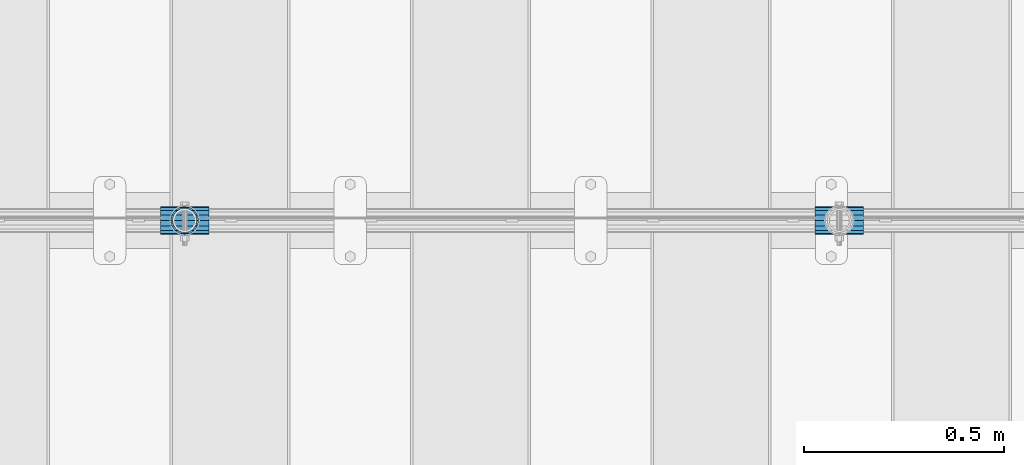
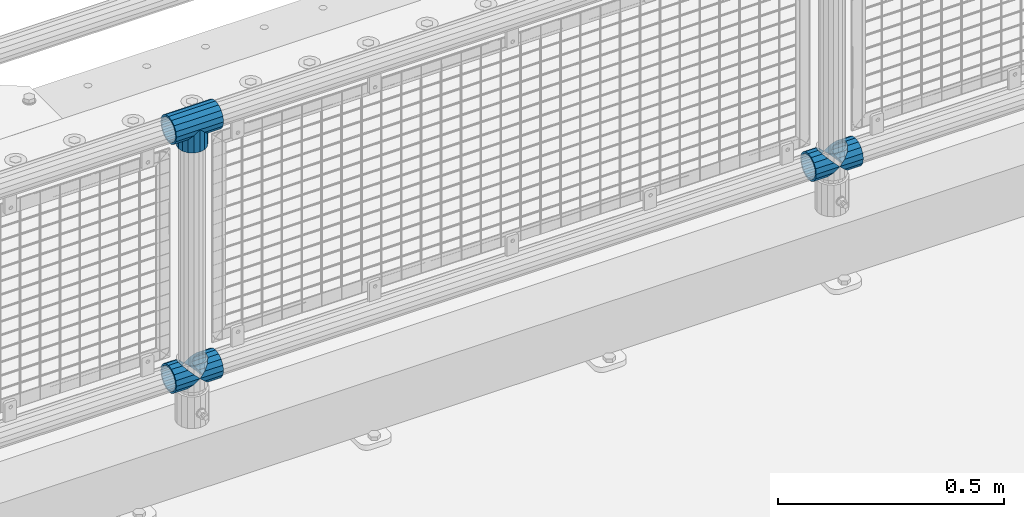
# One storey, part 147 of 242: 6 beams.
"""IFC2X3 building model written with IfcOpenShell, lengths in millimetres."""

from ifc_helpers import new_model, si_unit, frame, origin_with_axes, place, context, subcontext, project, spatial, faceted_brep, material, type_object, element, save


model = new_model("IFC2X3")

# Units and contexts
model_context = context("Model", 3, precision=1e-05, world=origin_with_axes())
body_context = subcontext(model_context, "Body", "Model", "MODEL_VIEW")
ifc_project = project(units=[si_unit("LENGTHUNIT", "METRE", prefix="MILLI"), si_unit("AREAUNIT", "SQUARE_METRE"), si_unit("VOLUMEUNIT", "CUBIC_METRE"), si_unit("MASSUNIT", "GRAM", prefix="KILO"), si_unit("TIMEUNIT", "SECOND"), si_unit("PLANEANGLEUNIT", "RADIAN"), si_unit("SOLIDANGLEUNIT", "STERADIAN"), si_unit("THERMODYNAMICTEMPERATUREUNIT", "DEGREE_CELSIUS"), si_unit("LUMINOUSINTENSITYUNIT", "LUMEN")], contexts=[model_context])

# Site, building, storey
site_placement = place(None, origin_with_axes())
site = spatial("IfcSite", under=ifc_project, at=site_placement, CompositionType="ELEMENT")
building_placement = place(site_placement, origin_with_axes())
building = spatial("IfcBuilding", under=site, at=building_placement, Name="Standard", CompositionType="ELEMENT")
storey_placement = place(building_placement, origin_with_axes())
storey = spatial("IfcBuildingStorey", under=building, at=storey_placement, Name="Undefined", CompositionType="ELEMENT", Elevation=0.0)

# Beams
ifc_material = material(Name="Misc_Undefined")
beam_type = type_object("IfcBeamType", PredefinedType="NOTDEFINED")
beam_1_placement = place(storey_placement, frame((-36990.15, -19335.5, 298.17), z_axis=(0.0, 1.0, 0.0), x_axis=(1.0, 0.0, 0.0)))
element("IfcBeam", 1, at=beam_1_placement, inside=storey, type_object=beam_type, material=ifc_material, context=body_context, shape_type="Brep", body=[
    faceted_brep([(60.1500000000015, 0.0, -35.1500000000015), (46.698677352364, 13.4513226476329, -32.4743655677703), (46.698677352364, -13.4513226476329, -32.4743655677703), (33.0273231408901, 21.4606908090117, 21.46069080901), (27.6756344322275, 26.8123795176754, 13.4513226476338), (27.6756344322275, 32.4743655677717, 13.4513226476338), (35.2951966412911, 24.8548033587072, 24.8548033587067), (35.2951966412911, 16.3810424080013, 24.8548033587067), (27.3102561882806, 28.0397438117175, 11.614442172282), (24.9999999999964, 30.35, 0.0), (24.9999999999964, 35.15, 0.0), (27.6756344322275, 26.8123795176754, -13.4513226476338), (27.6756344322275, 32.4743655677717, -13.4513226476338), (27.310256188277, 28.0397438117175, -11.614442172282), (35.2951966412911, 16.3810424080013, -24.8548033587067), (35.2951966412911, 24.8548033587072, -24.8548033587067), (33.0273231408937, 21.4606908090117, -21.46069080901), (40.061796877013, 11.6144421722805, -28.0397438117179), (43.5193396016293, 0.0, -30.3499999999985), (40.061796877013, -11.6144421722805, -28.0397438117179), (35.2951966412911, -16.3810424080078, -24.8548033587067), (35.2951966412911, -24.8548033587072, -24.8548033587067), (33.0273231408937, -21.4606908090117, -21.46069080901), (27.6756344322275, -26.8123795176754, -13.4513226476338), (27.6756344322275, -32.4743655677717, -13.4513226476338), (27.310256188277, -28.0397438117175, -11.614442172282), (24.9999999999964, -30.35, 0.0), (24.9999999999964, -35.15, 0.0), (27.3102561882806, -28.0397438117175, 11.614442172282), (27.6756344322275, -26.8123795176775, 13.4513226476338), (27.6756344322275, -32.4743655677717, 13.4513226476338), (33.0273231408901, -21.4606908090117, 21.46069080901), (35.2951966412911, -16.3810424080045, 24.8548033587067), (35.2951966412911, -24.8548033587072, 24.8548033587067), (60.1500000000015, 0.0, 35.1500000000015), (46.698677352364, -13.4513226476329, 32.4743655677703), (46.698677352364, 13.4513226476329, 32.4743655677703), (40.0617968770166, -11.6144421722805, 28.0397438117179), (43.5193396016257, 0.0, 30.3499999999985), (40.0617968770166, 11.6144421722805, 28.0397438117179), (0.0, -32.4743655677703, -13.4513226476338), (0.0, -24.8548033587067, -24.8548033587067), (0.0, -13.4513226476338, -32.4743655677739), (0.0, 0.0, -35.1500000000015), (0.0, 13.4513226476338, -32.4743655677739), (0.0, 24.8548033587067, -24.8548033587067), (0.0, 32.4743655677703, -13.4513226476338), (0.0, 35.1500000000015, 0.0), (0.0, 32.4743655677703, 13.4513226476338), (0.0, 24.8548033587067, 24.8548033587067), (0.0, 13.4513226476338, 32.4743655677739), (0.0, 0.0, 35.1500000000015), (0.0, -32.4743655677703, 13.4513226476338), (0.0, -35.1500000000015, 0.0), (0.0, -24.8548033587067, 24.8548033587067), (0.0, -13.4513226476338, 32.4743655677739), (0.0, -28.0397438117179, -11.6144421722784), (0.0, -21.46069080901, -21.4606908090136), (0.0, -11.614442172282, -28.0397438117143), (0.0, 0.0, -30.3499999999985), (0.0, 11.614442172282, -28.0397438117143), (0.0, 21.46069080901, -21.4606908090136), (0.0, 28.0397438117179, -11.6144421722784), (0.0, 30.3499999999985, 0.0), (0.0, 28.0397438117179, 11.6144421722784), (0.0, 21.46069080901, 21.4606908090136), (0.0, 11.614442172282, 28.0397438117143), (0.0, 0.0, 30.3499999999985), (0.0, -11.614442172282, 28.0397438117143), (0.0, -21.46069080901, 21.4606908090136), (0.0, -28.0397438117179, 11.6144421722784), (0.0, -30.3499999999985, 0.0)], [[[0, 1, 2]], [[3, 4, 5, 6, 7]], [[8, 9, 10, 5, 4]], [[11, 12, 10, 9, 13]], [[14, 15, 12, 11, 16]], [[2, 1, 15, 14, 17, 18, 19, 20, 21]], [[21, 20, 22, 23, 24]], [[24, 23, 25, 26, 27]], [[27, 26, 28, 29, 30]], [[30, 29, 31, 32, 33]], [[34, 35, 36]], [[33, 32, 37, 38, 39, 7, 6, 36, 35]], [[40, 41, 21, 24]], [[41, 42, 2, 21]], [[42, 43, 0, 2]], [[43, 44, 1, 0]], [[44, 45, 15, 1]], [[45, 46, 12, 15]], [[46, 47, 10, 12]], [[47, 48, 5, 10]], [[48, 49, 6, 5]], [[49, 50, 36, 6]], [[50, 51, 34, 36]], [[52, 53, 27, 30]], [[54, 52, 30, 33]], [[55, 54, 33, 35]], [[51, 55, 35, 34]], [[53, 40, 24, 27]], [[52, 54, 55, 51, 50, 49, 48, 47, 46, 45, 44, 43, 42, 41, 40, 53], [56, 57, 58, 59, 60, 61, 62, 63, 64, 65, 66, 67, 68, 69, 70, 71]], [[68, 67, 38, 37]], [[31, 69, 68, 37, 32]], [[28, 70, 69, 31, 29]], [[71, 70, 28, 26]], [[56, 71, 26, 25]], [[57, 56, 25, 23, 22]], [[58, 57, 22, 20, 19]], [[59, 58, 19, 18]], [[60, 59, 18, 17]], [[16, 61, 60, 17, 14]], [[13, 62, 61, 16, 11]], [[63, 62, 13, 9]], [[64, 63, 9, 8]], [[65, 64, 8, 4, 3]], [[66, 65, 3, 7, 39]], [[67, 66, 39, 38]]]),
])
beam_2_placement = place(storey_placement, frame((-36930.0, -19335.5, 298.17), z_axis=(0.0, 1.0, 0.0), x_axis=(1.0, 0.0, 0.0)))
element("IfcBeam", 2, at=beam_2_placement, inside=storey, type_object=beam_type, material=ifc_material, context=body_context, shape_type="Brep", body=[
    faceted_brep([(13.4513226476338, 13.4513226476329, 32.4743655677703), (13.4513226476338, -13.4513226476329, 32.4743655677703), (0.0, 0.0, 35.1500000000015), (27.122676859115, -21.4606908090117, -21.46069080901), (24.8548033587067, -16.3810424080019, -24.8548033587067), (24.8548033587067, -24.8548033587072, -24.8548033587067), (32.4743655677739, -32.4743655677717, -13.4513226476338), (32.4743655677739, -26.8123795176754, -13.4513226476338), (0.0, 0.0, -35.1500000000015), (13.4513226476338, -13.4513226476329, -32.4743655677703), (13.4513226476338, 13.4513226476329, -32.4743655677703), (20.0882031229849, -11.6144421722805, -28.0397438117179), (16.6306603983758, 0.0, -30.3499999999985), (20.0882031229849, 11.6144421722805, -28.0397438117179), (24.8548033587067, 16.3810424079986, -24.8548033587067), (24.8548033587067, 24.8548033587072, -24.8548033587067), (27.122676859115, 21.4606908090117, -21.46069080901), (32.4743655677739, 26.8123795176776, -13.4513226476338), (32.4743655677739, 32.4743655677717, -13.4513226476338), (32.8397438117099, 28.0397438117175, -11.614442172282), (35.1500000000015, 30.35, 0.0), (35.1500000000015, 35.1499999999996, 0.0), (32.8397438117172, 28.0397438117175, 11.614442172282), (32.4743655677739, 26.8123795176754, 13.4513226476338), (32.4743655677739, 32.4743655677717, 13.4513226476338), (27.1226768591077, 21.4606908090117, 21.46069080901), (24.8548033587067, 16.3810424080019, 24.8548033587067), (24.8548033587067, 24.8548033587072, 24.8548033587067), (20.0882031229849, 11.6144421722805, 28.0397438117179), (16.6306603983685, 0.0, 30.3499999999985), (20.0882031229849, -11.6144421722805, 28.0397438117179), (24.8548033587067, -16.3810424080019, 24.8548033587067), (24.8548033587067, -24.8548033587072, 24.8548033587067), (32.4743655677739, -26.8123795176754, 13.4513226476338), (32.4743655677739, -32.4743655677717, 13.4513226476338), (27.1226768591077, -21.4606908090117, 21.46069080901), (35.1500000000015, -30.35, 0.0), (35.1500000000015, -35.15, 0.0), (32.8397438117172, -28.0397438117175, 11.614442172282), (32.8397438117099, -28.0397438117175, -11.614442172282), (60.1500000000015, -24.8548033587072, -24.8548033587067), (60.1500000000015, -32.4743655677717, -13.4513226476338), (60.1500000000015, -13.4513226476329, -32.4743655677703), (60.1500000000015, 0.0, -35.1500000000015), (60.1500000000015, 13.4513226476329, -32.4743655677703), (60.1500000000015, 24.8548033587072, -24.8548033587067), (60.1500000000015, 32.4743655677717, -13.4513226476338), (60.1500000000015, 35.15, 0.0), (60.1500000000015, 32.4743655677717, 13.4513226476338), (60.1500000000015, 24.8548033587072, 24.8548033587067), (60.1500000000015, 13.4513226476329, 32.4743655677703), (60.1500000000015, 0.0, 35.1500000000015), (60.1500000000015, -13.4513226476329, 32.4743655677703), (60.1500000000015, -24.8548033587072, 24.8548033587067), (60.1500000000015, -32.4743655677717, 13.4513226476338), (60.1500000000015, -35.15, 0.0), (60.1500000000015, -21.4606908090117, 21.46069080901), (60.1500000000015, -11.6144421722805, 28.0397438117179), (60.1500000000015, 0.0, 30.3499999999985), (60.1500000000015, 11.6144421722805, 28.0397438117179), (60.1500000000015, 21.4606908090117, 21.46069080901), (60.1500000000015, 28.0397438117175, 11.614442172282), (60.1500000000015, 30.35, 0.0), (60.1500000000015, 28.0397438117175, -11.614442172282), (60.1500000000015, 21.4606908090117, -21.46069080901), (60.1500000000015, 11.6144421722805, -28.0397438117179), (60.1500000000015, 0.0, -30.3499999999985), (60.1500000000015, -11.6144421722805, -28.0397438117179), (60.1500000000015, -21.4606908090117, -21.46069080901), (60.1500000000015, -28.0397438117175, -11.614442172282), (60.1500000000015, -30.35, 0.0), (60.1500000000015, -28.0397438117175, 11.614442172282)], [[[0, 1, 2]], [[3, 4, 5, 6, 7]], [[8, 9, 10]], [[10, 9, 5, 4, 11, 12, 13, 14, 15]], [[15, 14, 16, 17, 18]], [[18, 17, 19, 20, 21]], [[21, 20, 22, 23, 24]], [[24, 23, 25, 26, 27]], [[27, 26, 28, 29, 30, 31, 32, 1, 0]], [[33, 34, 32, 31, 35]], [[36, 37, 34, 33, 38]], [[39, 7, 6, 37, 36]], [[40, 41, 6, 5]], [[42, 40, 5, 9]], [[43, 42, 9, 8]], [[44, 43, 8, 10]], [[45, 44, 10, 15]], [[46, 45, 15, 18]], [[47, 46, 18, 21]], [[48, 47, 21, 24]], [[49, 48, 24, 27]], [[50, 49, 27, 0]], [[51, 50, 0, 2]], [[52, 51, 2, 1]], [[53, 52, 1, 32]], [[54, 53, 32, 34]], [[55, 54, 34, 37]], [[41, 55, 37, 6]], [[40, 42, 43, 44, 45, 46, 47, 48, 49, 50, 51, 52, 53, 54, 55, 41], [56, 57, 58, 59, 60, 61, 62, 63, 64, 65, 66, 67, 68, 69, 70, 71]], [[71, 70, 36, 38]], [[35, 56, 71, 38, 33]], [[30, 57, 56, 35, 31]], [[58, 57, 30, 29]], [[59, 58, 29, 28]], [[60, 59, 28, 26, 25]], [[61, 60, 25, 23, 22]], [[62, 61, 22, 20]], [[63, 62, 20, 19]], [[16, 64, 63, 19, 17]], [[13, 65, 64, 16, 14]], [[66, 65, 13, 12]], [[67, 66, 12, 11]], [[68, 67, 11, 4, 3]], [[69, 68, 3, 7, 39]], [[70, 69, 39, 36]]]),
])
beam_3_placement = place(storey_placement, frame((-38623.15, -19335.5, 298.17), z_axis=(0.0, 1.0, 0.0), x_axis=(1.0, 0.0, 0.0)))
element("IfcBeam", 3, at=beam_3_placement, inside=storey, type_object=beam_type, material=ifc_material, context=body_context, shape_type="Brep", body=[
    faceted_brep([(60.1500000000015, 0.0, -35.1500000000015), (46.698677352364, 13.4513226476329, -32.4743655677703), (46.698677352364, -13.4513226476329, -32.4743655677703), (33.0273231408901, 21.4606908090117, 21.46069080901), (27.6756344322275, 26.8123795176754, 13.4513226476338), (27.6756344322275, 32.4743655677717, 13.4513226476338), (35.2951966412911, 24.8548033587072, 24.8548033587067), (35.2951966412911, 16.3810424080013, 24.8548033587067), (27.3102561882806, 28.0397438117175, 11.614442172282), (24.9999999999964, 30.35, 0.0), (24.9999999999964, 35.15, 0.0), (27.6756344322275, 26.8123795176754, -13.4513226476338), (27.6756344322275, 32.4743655677717, -13.4513226476338), (27.310256188277, 28.0397438117175, -11.614442172282), (35.2951966412911, 16.3810424080013, -24.8548033587067), (35.2951966412911, 24.8548033587072, -24.8548033587067), (33.0273231408937, 21.4606908090117, -21.46069080901), (40.061796877013, 11.6144421722805, -28.0397438117179), (43.5193396016293, 0.0, -30.3499999999985), (40.061796877013, -11.6144421722805, -28.0397438117179), (35.2951966412911, -16.3810424080078, -24.8548033587067), (35.2951966412911, -24.8548033587072, -24.8548033587067), (33.0273231408937, -21.4606908090117, -21.46069080901), (27.6756344322275, -26.8123795176754, -13.4513226476338), (27.6756344322275, -32.4743655677717, -13.4513226476338), (27.310256188277, -28.0397438117175, -11.614442172282), (24.9999999999964, -30.35, 0.0), (24.9999999999964, -35.15, 0.0), (27.3102561882806, -28.0397438117175, 11.614442172282), (27.6756344322275, -26.8123795176775, 13.4513226476338), (27.6756344322275, -32.4743655677717, 13.4513226476338), (33.0273231408901, -21.4606908090117, 21.46069080901), (35.2951966412911, -16.3810424080045, 24.8548033587067), (35.2951966412911, -24.8548033587072, 24.8548033587067), (60.1500000000015, 0.0, 35.1500000000015), (46.698677352364, -13.4513226476329, 32.4743655677703), (46.698677352364, 13.4513226476329, 32.4743655677703), (40.0617968770166, -11.6144421722805, 28.0397438117179), (43.5193396016257, 0.0, 30.3499999999985), (40.0617968770166, 11.6144421722805, 28.0397438117179), (0.0, -32.4743655677703, -13.4513226476338), (0.0, -24.8548033587067, -24.8548033587067), (0.0, -13.4513226476338, -32.4743655677739), (0.0, 0.0, -35.1500000000015), (0.0, 13.4513226476338, -32.4743655677739), (0.0, 24.8548033587067, -24.8548033587067), (0.0, 32.4743655677703, -13.4513226476338), (0.0, 35.1500000000015, 0.0), (0.0, 32.4743655677703, 13.4513226476338), (0.0, 24.8548033587067, 24.8548033587067), (0.0, 13.4513226476338, 32.4743655677739), (0.0, 0.0, 35.1500000000015), (0.0, -32.4743655677703, 13.4513226476338), (0.0, -35.1500000000015, 0.0), (0.0, -24.8548033587067, 24.8548033587067), (0.0, -13.4513226476338, 32.4743655677739), (0.0, -28.0397438117179, -11.6144421722784), (0.0, -21.46069080901, -21.4606908090136), (0.0, -11.614442172282, -28.0397438117143), (0.0, 0.0, -30.3499999999985), (0.0, 11.614442172282, -28.0397438117143), (0.0, 21.46069080901, -21.4606908090136), (0.0, 28.0397438117179, -11.6144421722784), (0.0, 30.3499999999985, 0.0), (0.0, 28.0397438117179, 11.6144421722784), (0.0, 21.46069080901, 21.4606908090136), (0.0, 11.614442172282, 28.0397438117143), (0.0, 0.0, 30.3499999999985), (0.0, -11.614442172282, 28.0397438117143), (0.0, -21.46069080901, 21.4606908090136), (0.0, -28.0397438117179, 11.6144421722784), (0.0, -30.3499999999985, 0.0)], [[[0, 1, 2]], [[3, 4, 5, 6, 7]], [[8, 9, 10, 5, 4]], [[11, 12, 10, 9, 13]], [[14, 15, 12, 11, 16]], [[2, 1, 15, 14, 17, 18, 19, 20, 21]], [[21, 20, 22, 23, 24]], [[24, 23, 25, 26, 27]], [[27, 26, 28, 29, 30]], [[30, 29, 31, 32, 33]], [[34, 35, 36]], [[33, 32, 37, 38, 39, 7, 6, 36, 35]], [[40, 41, 21, 24]], [[41, 42, 2, 21]], [[42, 43, 0, 2]], [[43, 44, 1, 0]], [[44, 45, 15, 1]], [[45, 46, 12, 15]], [[46, 47, 10, 12]], [[47, 48, 5, 10]], [[48, 49, 6, 5]], [[49, 50, 36, 6]], [[50, 51, 34, 36]], [[52, 53, 27, 30]], [[54, 52, 30, 33]], [[55, 54, 33, 35]], [[51, 55, 35, 34]], [[53, 40, 24, 27]], [[52, 54, 55, 51, 50, 49, 48, 47, 46, 45, 44, 43, 42, 41, 40, 53], [56, 57, 58, 59, 60, 61, 62, 63, 64, 65, 66, 67, 68, 69, 70, 71]], [[68, 67, 38, 37]], [[31, 69, 68, 37, 32]], [[28, 70, 69, 31, 29]], [[71, 70, 28, 26]], [[56, 71, 26, 25]], [[57, 56, 25, 23, 22]], [[58, 57, 22, 20, 19]], [[59, 58, 19, 18]], [[60, 59, 18, 17]], [[16, 61, 60, 17, 14]], [[13, 62, 61, 16, 11]], [[63, 62, 13, 9]], [[64, 63, 9, 8]], [[65, 64, 8, 4, 3]], [[66, 65, 3, 7, 39]], [[67, 66, 39, 38]]]),
])
beam_4_placement = place(storey_placement, frame((-38563.0, -19335.5, 298.17), z_axis=(0.0, 1.0, 0.0), x_axis=(1.0, 0.0, 0.0)))
element("IfcBeam", 4, at=beam_4_placement, inside=storey, type_object=beam_type, material=ifc_material, context=body_context, shape_type="Brep", body=[
    faceted_brep([(13.4513226476338, 13.4513226476329, 32.4743655677703), (13.4513226476338, -13.4513226476329, 32.4743655677703), (0.0, 0.0, 35.1500000000015), (27.122676859115, -21.4606908090117, -21.46069080901), (24.8548033587067, -16.3810424080019, -24.8548033587067), (24.8548033587067, -24.8548033587072, -24.8548033587067), (32.4743655677739, -32.4743655677717, -13.4513226476338), (32.4743655677739, -26.8123795176754, -13.4513226476338), (0.0, 0.0, -35.1500000000015), (13.4513226476338, -13.4513226476329, -32.4743655677703), (13.4513226476338, 13.4513226476329, -32.4743655677703), (20.0882031229849, -11.6144421722805, -28.0397438117179), (16.6306603983758, 0.0, -30.3499999999985), (20.0882031229849, 11.6144421722805, -28.0397438117179), (24.8548033587067, 16.3810424079986, -24.8548033587067), (24.8548033587067, 24.8548033587072, -24.8548033587067), (27.122676859115, 21.4606908090117, -21.46069080901), (32.4743655677739, 26.8123795176776, -13.4513226476338), (32.4743655677739, 32.4743655677717, -13.4513226476338), (32.8397438117099, 28.0397438117175, -11.614442172282), (35.1500000000015, 30.35, 0.0), (35.1500000000015, 35.1499999999996, 0.0), (32.8397438117172, 28.0397438117175, 11.614442172282), (32.4743655677739, 26.8123795176754, 13.4513226476338), (32.4743655677739, 32.4743655677717, 13.4513226476338), (27.1226768591077, 21.4606908090117, 21.46069080901), (24.8548033587067, 16.3810424080019, 24.8548033587067), (24.8548033587067, 24.8548033587072, 24.8548033587067), (20.0882031229849, 11.6144421722805, 28.0397438117179), (16.6306603983685, 0.0, 30.3499999999985), (20.0882031229849, -11.6144421722805, 28.0397438117179), (24.8548033587067, -16.3810424080019, 24.8548033587067), (24.8548033587067, -24.8548033587072, 24.8548033587067), (32.4743655677739, -26.8123795176754, 13.4513226476338), (32.4743655677739, -32.4743655677717, 13.4513226476338), (27.1226768591077, -21.4606908090117, 21.46069080901), (35.1500000000015, -30.35, 0.0), (35.1500000000015, -35.15, 0.0), (32.8397438117172, -28.0397438117175, 11.614442172282), (32.8397438117099, -28.0397438117175, -11.614442172282), (60.1500000000015, -24.8548033587072, -24.8548033587067), (60.1500000000015, -32.4743655677717, -13.4513226476338), (60.1500000000015, -13.4513226476329, -32.4743655677703), (60.1500000000015, 0.0, -35.1500000000015), (60.1500000000015, 13.4513226476329, -32.4743655677703), (60.1500000000015, 24.8548033587072, -24.8548033587067), (60.1500000000015, 32.4743655677717, -13.4513226476338), (60.1500000000015, 35.15, 0.0), (60.1500000000015, 32.4743655677717, 13.4513226476338), (60.1500000000015, 24.8548033587072, 24.8548033587067), (60.1500000000015, 13.4513226476329, 32.4743655677703), (60.1500000000015, 0.0, 35.1500000000015), (60.1500000000015, -13.4513226476329, 32.4743655677703), (60.1500000000015, -24.8548033587072, 24.8548033587067), (60.1500000000015, -32.4743655677717, 13.4513226476338), (60.1500000000015, -35.15, 0.0), (60.1500000000015, -21.4606908090117, 21.46069080901), (60.1500000000015, -11.6144421722805, 28.0397438117179), (60.1500000000015, 0.0, 30.3499999999985), (60.1500000000015, 11.6144421722805, 28.0397438117179), (60.1500000000015, 21.4606908090117, 21.46069080901), (60.1500000000015, 28.0397438117175, 11.614442172282), (60.1500000000015, 30.35, 0.0), (60.1500000000015, 28.0397438117175, -11.614442172282), (60.1500000000015, 21.4606908090117, -21.46069080901), (60.1500000000015, 11.6144421722805, -28.0397438117179), (60.1500000000015, 0.0, -30.3499999999985), (60.1500000000015, -11.6144421722805, -28.0397438117179), (60.1500000000015, -21.4606908090117, -21.46069080901), (60.1500000000015, -28.0397438117175, -11.614442172282), (60.1500000000015, -30.35, 0.0), (60.1500000000015, -28.0397438117175, 11.614442172282)], [[[0, 1, 2]], [[3, 4, 5, 6, 7]], [[8, 9, 10]], [[10, 9, 5, 4, 11, 12, 13, 14, 15]], [[15, 14, 16, 17, 18]], [[18, 17, 19, 20, 21]], [[21, 20, 22, 23, 24]], [[24, 23, 25, 26, 27]], [[27, 26, 28, 29, 30, 31, 32, 1, 0]], [[33, 34, 32, 31, 35]], [[36, 37, 34, 33, 38]], [[39, 7, 6, 37, 36]], [[40, 41, 6, 5]], [[42, 40, 5, 9]], [[43, 42, 9, 8]], [[44, 43, 8, 10]], [[45, 44, 10, 15]], [[46, 45, 15, 18]], [[47, 46, 18, 21]], [[48, 47, 21, 24]], [[49, 48, 24, 27]], [[50, 49, 27, 0]], [[51, 50, 0, 2]], [[52, 51, 2, 1]], [[53, 52, 1, 32]], [[54, 53, 32, 34]], [[55, 54, 34, 37]], [[41, 55, 37, 6]], [[40, 42, 43, 44, 45, 46, 47, 48, 49, 50, 51, 52, 53, 54, 55, 41], [56, 57, 58, 59, 60, 61, 62, 63, 64, 65, 66, 67, 68, 69, 70, 71]], [[71, 70, 36, 38]], [[35, 56, 71, 38, 33]], [[30, 57, 56, 35, 31]], [[58, 57, 30, 29]], [[59, 58, 29, 28]], [[60, 59, 28, 26, 25]], [[61, 60, 25, 23, 22]], [[62, 61, 22, 20]], [[63, 62, 20, 19]], [[16, 64, 63, 19, 17]], [[13, 65, 64, 16, 14]], [[66, 65, 13, 12]], [[67, 66, 12, 11]], [[68, 67, 11, 4, 3]], [[69, 68, 3, 7, 39]], [[70, 69, 39, 36]]]),
])
beam_5_placement = place(storey_placement, frame((-38563.0, -19335.5, 969.849999999999), z_axis=(0.0, 1.0, 0.0), x_axis=(0.0, 0.0, -1.0)))
element("IfcBeam", 5, at=beam_5_placement, inside=storey, type_object=beam_type, material=ifc_material, context=body_context, shape_type="Brep", body=[
    faceted_brep([(13.4513226476338, 13.4513226476329, 32.4743655677703), (13.4513226476338, -13.4513226476329, 32.4743655677703), (0.0, 0.0, 35.1500000000015), (27.122676859115, -21.4606908090117, -21.46069080901), (24.8548033587067, -16.3810424080019, -24.8548033587067), (24.8548033587067, -24.8548033587072, -24.8548033587067), (32.4743655677739, -32.4743655677717, -13.4513226476338), (32.4743655677739, -26.8123795176754, -13.4513226476338), (0.0, 0.0, -35.1500000000015), (13.4513226476338, -13.4513226476329, -32.4743655677703), (13.4513226476338, 13.4513226476329, -32.4743655677703), (20.0882031229849, -11.6144421722805, -28.0397438117179), (16.6306603983758, 0.0, -30.3499999999985), (20.0882031229849, 11.6144421722805, -28.0397438117179), (24.8548033587067, 16.3810424079986, -24.8548033587067), (24.8548033587067, 24.8548033587072, -24.8548033587067), (27.122676859115, 21.4606908090117, -21.46069080901), (32.4743655677739, 26.8123795176776, -13.4513226476338), (32.4743655677739, 32.4743655677717, -13.4513226476338), (32.8397438117099, 28.0397438117175, -11.614442172282), (35.1500000000015, 30.35, 0.0), (35.1500000000015, 35.1499999999996, 0.0), (32.8397438117172, 28.0397438117175, 11.614442172282), (32.4743655677739, 26.8123795176754, 13.4513226476338), (32.4743655677739, 32.4743655677717, 13.4513226476338), (27.1226768591077, 21.4606908090117, 21.46069080901), (24.8548033587067, 16.3810424080019, 24.8548033587067), (24.8548033587067, 24.8548033587072, 24.8548033587067), (20.0882031229849, 11.6144421722805, 28.0397438117179), (16.6306603983685, 0.0, 30.3499999999985), (20.0882031229849, -11.6144421722805, 28.0397438117179), (24.8548033587067, -16.3810424080019, 24.8548033587067), (24.8548033587067, -24.8548033587072, 24.8548033587067), (32.4743655677739, -26.8123795176754, 13.4513226476338), (32.4743655677739, -32.4743655677717, 13.4513226476338), (27.1226768591077, -21.4606908090117, 21.46069080901), (35.1500000000015, -30.35, 0.0), (35.1500000000015, -35.15, 0.0), (32.8397438117172, -28.0397438117175, 11.614442172282), (32.8397438117099, -28.0397438117175, -11.614442172282), (60.1500000000015, -24.8548033587072, -24.8548033587067), (60.1500000000015, -32.4743655677717, -13.4513226476338), (60.1500000000015, -13.4513226476329, -32.4743655677703), (60.1500000000015, 0.0, -35.1500000000015), (60.1500000000015, 13.4513226476329, -32.4743655677703), (60.1500000000015, 24.8548033587072, -24.8548033587067), (60.1500000000015, 32.4743655677717, -13.4513226476338), (60.1500000000015, 35.15, 0.0), (60.1500000000015, 32.4743655677717, 13.4513226476338), (60.1500000000015, 24.8548033587072, 24.8548033587067), (60.1500000000015, 13.4513226476329, 32.4743655677703), (60.1500000000015, 0.0, 35.1500000000015), (60.1500000000015, -13.4513226476329, 32.4743655677703), (60.1500000000015, -24.8548033587072, 24.8548033587067), (60.1500000000015, -32.4743655677717, 13.4513226476338), (60.1500000000015, -35.15, 0.0), (60.1500000000015, -21.4606908090117, 21.46069080901), (60.1500000000015, -11.6144421722805, 28.0397438117179), (60.1500000000015, 0.0, 30.3499999999985), (60.1500000000015, 11.6144421722805, 28.0397438117179), (60.1500000000015, 21.4606908090117, 21.46069080901), (60.1500000000015, 28.0397438117175, 11.614442172282), (60.1500000000015, 30.35, 0.0), (60.1500000000015, 28.0397438117175, -11.614442172282), (60.1500000000015, 21.4606908090117, -21.46069080901), (60.1500000000015, 11.6144421722805, -28.0397438117179), (60.1500000000015, 0.0, -30.3499999999985), (60.1500000000015, -11.6144421722805, -28.0397438117179), (60.1500000000015, -21.4606908090117, -21.46069080901), (60.1500000000015, -28.0397438117175, -11.614442172282), (60.1500000000015, -30.35, 0.0), (60.1500000000015, -28.0397438117175, 11.614442172282)], [[[0, 1, 2]], [[3, 4, 5, 6, 7]], [[8, 9, 10]], [[10, 9, 5, 4, 11, 12, 13, 14, 15]], [[15, 14, 16, 17, 18]], [[18, 17, 19, 20, 21]], [[21, 20, 22, 23, 24]], [[24, 23, 25, 26, 27]], [[27, 26, 28, 29, 30, 31, 32, 1, 0]], [[33, 34, 32, 31, 35]], [[36, 37, 34, 33, 38]], [[39, 7, 6, 37, 36]], [[40, 41, 6, 5]], [[42, 40, 5, 9]], [[43, 42, 9, 8]], [[44, 43, 8, 10]], [[45, 44, 10, 15]], [[46, 45, 15, 18]], [[47, 46, 18, 21]], [[48, 47, 21, 24]], [[49, 48, 24, 27]], [[50, 49, 27, 0]], [[51, 50, 0, 2]], [[52, 51, 2, 1]], [[53, 52, 1, 32]], [[54, 53, 32, 34]], [[55, 54, 34, 37]], [[41, 55, 37, 6]], [[40, 42, 43, 44, 45, 46, 47, 48, 49, 50, 51, 52, 53, 54, 55, 41], [56, 57, 58, 59, 60, 61, 62, 63, 64, 65, 66, 67, 68, 69, 70, 71]], [[71, 70, 36, 38]], [[35, 56, 71, 38, 33]], [[30, 57, 56, 35, 31]], [[58, 57, 30, 29]], [[59, 58, 29, 28]], [[60, 59, 28, 26, 25]], [[61, 60, 25, 23, 22]], [[62, 61, 22, 20]], [[63, 62, 20, 19]], [[16, 64, 63, 19, 17]], [[13, 65, 64, 16, 14]], [[66, 65, 13, 12]], [[67, 66, 12, 11]], [[68, 67, 11, 4, 3]], [[69, 68, 3, 7, 39]], [[70, 69, 39, 36]]]),
])
beam_6_placement = place(storey_placement, frame((-38623.15, -19335.5, 969.849999999999), z_axis=(0.0, 0.0, 1.0), x_axis=(1.0, 0.0, 0.0)))
element("IfcBeam", 6, at=beam_6_placement, inside=storey, type_object=beam_type, material=ifc_material, context=body_context, shape_type="Brep", body=[
    faceted_brep([(88.1897438117194, -11.614442172282, -28.0397438117176), (88.1897438117194, -11.614442172282, -32.8397438117175), (86.9623795176813, -13.4513226476338, -32.4743655677718), (81.6106908090114, -21.46069080901, -27.12267685911), (81.6106908090114, -21.46069080901, -21.4606908090117), (76.5310424080017, -24.8548033587067, -24.8548033587072), (71.7644421722835, -28.0397438117179, -20.0882031229829), (71.7644421722835, -28.0397438117179, -11.6144421722805), (60.1500000000015, -30.3499999999985, -16.6306603983671), (60.1500000000015, -30.35, 0.0), (48.5355578277195, -28.0397438117179, -20.0882031229829), (48.5355578277195, -28.0397438117179, -11.6144421722805), (43.7689575920012, -24.8548033587067, -24.8548033587072), (38.6893091909915, -21.46069080901, -27.12267685911), (38.6893091909915, -21.46069080901, -21.4606908090117), (33.3376204823289, -13.4513226476338, -32.4743655677718), (32.1102561882835, -11.614442172282, -32.8397438117175), (32.1102561882835, -11.614442172282, -28.0397438117176), (29.8000000000029, 0.0, -35.15), (29.8000000000029, 0.0, -30.35), (32.1102561882835, 11.614442172282, -32.8397438117171), (32.1102561882835, 11.614442172282, -28.0397438117176), (33.3376204823253, 13.4513226476338, -32.4743655677718), (38.6893091909915, 21.46069080901, -27.12267685911), (38.6893091909915, 21.46069080901, -21.4606908090117), (43.7689575920012, 24.8548033587067, -24.8548033587072), (48.5355578277195, 28.0397438117179, -20.0882031229861), (48.5355578277195, 28.0397438117179, -11.6144421722805), (60.1500000000015, 30.3499999999985, -16.6306603983737), (60.1500000000015, 30.35, 0.0), (71.7644421722835, 28.0397438117179, -20.0882031229861), (71.7644421722835, 28.0397438117179, -11.6144421722805), (76.5310424080017, 24.8548033587067, -24.8548033587072), (81.6106908090114, 21.46069080901, -27.12267685911), (81.6106908090114, 21.46069080901, -21.4606908090117), (86.9623795176667, 13.4513226476338, -32.4743655677718), (88.1897438117194, 11.614442172282, -32.8397438117171), (88.1897438117194, 11.614442172282, -28.0397438117176), (90.5, 0.0, -35.15), (90.5, 0.0, -30.35), (0.0, -21.46069080901, -21.4606908090136), (0.0, -28.0397438117179, -11.6144421722784), (0.0, -11.614442172282, -28.0397438117143), (0.0, 0.0, -30.3499999999985), (0.0, 11.614442172282, -28.0397438117143), (0.0, 21.46069080901, -21.4606908090136), (0.0, 28.0397438117179, -11.6144421722784), (0.0, 30.3499999999985, 0.0), (0.0, 32.4743655677703, -13.4513226476338), (0.0, 35.1500000000015, 0.0), (120.299999999999, 35.1500000000015, 0.0), (120.299999999999, 32.4743655677703, -13.4513226476329), (0.0, 32.4743655677703, 13.4513226476338), (120.299999999999, 32.4743655677703, 13.4513226476329), (0.0, 24.8548033587067, 24.8548033587067), (120.299999999999, 24.8548033587067, 24.8548033587072), (0.0, 13.4513226476338, 32.4743655677739), (120.299999999999, 13.4513226476338, 32.4743655677718), (0.0, 0.0, 35.1500000000015), (120.299999999999, 0.0, 35.15), (0.0, -13.4513226476338, 32.4743655677739), (120.299999999999, -13.4513226476338, 32.4743655677718), (0.0, -24.8548033587067, 24.8548033587067), (120.299999999999, -24.8548033587067, 24.8548033587072), (0.0, -32.4743655677703, 13.4513226476338), (120.299999999999, -32.4743655677703, 13.4513226476329), (0.0, -35.1500000000015, 0.0), (120.299999999999, -35.1500000000015, 0.0), (0.0, -32.4743655677703, -13.4513226476338), (120.299999999999, -32.4743655677703, -13.4513226476329), (0.0, 24.8548033587067, -24.8548033587067), (0.0, 13.4513226476338, -32.4743655677739), (0.0, 0.0, -35.1500000000015), (0.0, -13.4513226476338, -32.4743655677739), (0.0, -24.8548033587067, -24.8548033587067), (0.0, 28.0397438117179, 11.6144421722784), (0.0, 21.46069080901, 21.4606908090136), (0.0, 11.614442172282, 28.0397438117143), (0.0, 0.0, 30.3499999999985), (0.0, -11.614442172282, 28.0397438117143), (0.0, -21.46069080901, 21.4606908090136), (0.0, -28.0397438117179, 11.6144421722784), (0.0, -30.3499999999985, 0.0), (120.299999999999, -30.3499999999985, 0.0), (120.299999999999, -28.0397438117179, -11.6144421722805), (120.299999999999, -21.46069080901, -21.4606908090117), (120.299999999999, -11.614442172282, -28.0397438117176), (120.299999999999, 0.0, -30.35), (120.299999999999, 21.46069080901, -21.4606908090117), (120.299999999999, 28.0397438117179, -11.6144421722805), (120.299999999999, 11.614442172282, -28.0397438117176), (120.299999999999, 30.3499999999985, 0.0), (120.299999999999, 28.0397438117179, 11.6144421722805), (120.299999999999, 21.46069080901, 21.4606908090117), (120.299999999999, 11.614442172282, 28.0397438117176), (120.299999999999, 0.0, 30.35), (120.299999999999, -11.614442172282, 28.0397438117176), (120.299999999999, -21.46069080901, 21.4606908090117), (120.299999999999, -28.0397438117179, 11.6144421722805), (120.299999999999, -24.8548033587067, -24.8548033587072), (120.299999999999, -13.4513226476338, -32.4743655677718), (120.299999999999, 0.0, -35.15), (120.299999999999, 13.4513226476338, -32.4743655677718), (120.299999999999, 24.8548033587067, -24.8548033587072)], [[[0, 1, 2, 3, 4]], [[4, 3, 5, 6, 7]], [[7, 6, 8, 9]], [[9, 8, 10, 11]], [[11, 10, 12, 13, 14]], [[14, 13, 15, 16, 17]], [[17, 16, 18, 19]], [[19, 18, 20, 21]], [[21, 20, 22, 23, 24]], [[24, 23, 25, 26, 27]], [[27, 26, 28, 29]], [[29, 28, 30, 31]], [[31, 30, 32, 33, 34]], [[34, 33, 35, 36, 37]], [[37, 36, 38, 39]], [[39, 38, 1, 0]], [[40, 41, 11, 14]], [[42, 40, 14, 17]], [[43, 42, 17, 19]], [[44, 43, 19, 21]], [[45, 44, 21, 24]], [[46, 45, 24, 27]], [[47, 46, 27, 29]], [[48, 49, 50, 51]], [[49, 52, 53, 50]], [[52, 54, 55, 53]], [[54, 56, 57, 55]], [[56, 58, 59, 57]], [[58, 60, 61, 59]], [[60, 62, 63, 61]], [[62, 64, 65, 63]], [[64, 66, 67, 65]], [[66, 68, 69, 67]], [[64, 62, 60, 58, 56, 54, 52, 49, 48, 70, 71, 72, 73, 74, 68, 66], [41, 40, 42, 43, 44, 45, 46, 47, 75, 76, 77, 78, 79, 80, 81, 82]], [[41, 82, 9, 11]], [[83, 84, 7, 9]], [[84, 85, 4, 7]], [[85, 86, 0, 4]], [[86, 87, 39, 0]], [[88, 89, 31, 34]], [[90, 88, 34, 37]], [[87, 90, 37, 39]], [[89, 91, 29, 31]], [[75, 47, 29, 91, 92]], [[76, 75, 92, 93]], [[77, 76, 93, 94]], [[78, 77, 94, 95]], [[79, 78, 95, 96]], [[80, 79, 96, 97]], [[81, 80, 97, 98]], [[9, 82, 81, 98, 83]], [[99, 100, 101, 102, 103, 51, 50, 53, 55, 57, 59, 61, 63, 65, 67, 69], [97, 96, 95, 94, 93, 92, 91, 89, 88, 90, 87, 86, 85, 84, 83, 98]], [[35, 102, 101, 38, 36]], [[32, 103, 102, 35, 33]], [[28, 26, 25, 70, 48, 51, 103, 32, 30]], [[22, 71, 70, 25, 23]], [[18, 72, 71, 22, 20]], [[73, 72, 18, 16, 15]], [[74, 73, 15, 13, 12]], [[99, 69, 68, 74, 12, 10, 8, 6, 5]], [[100, 99, 5, 3, 2]], [[101, 100, 2, 1, 38]]]),
])

save(model, "model.ifc")
